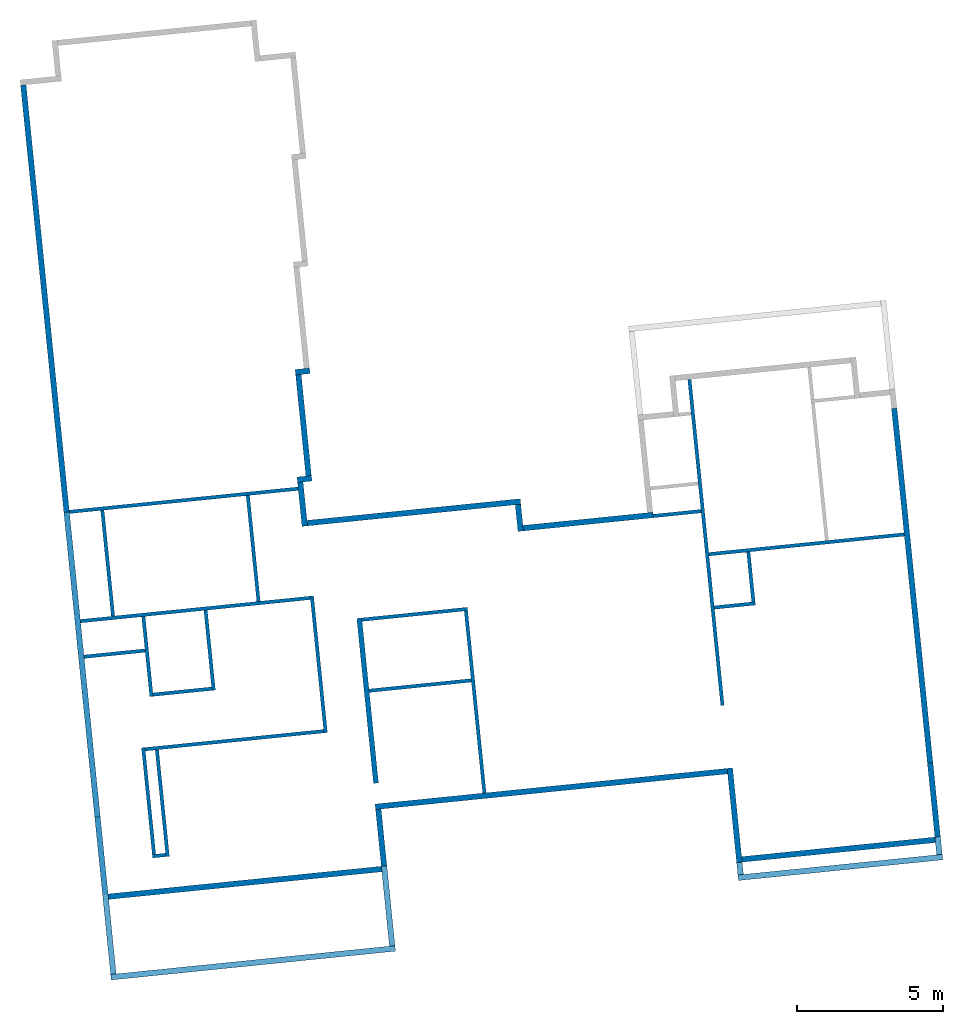
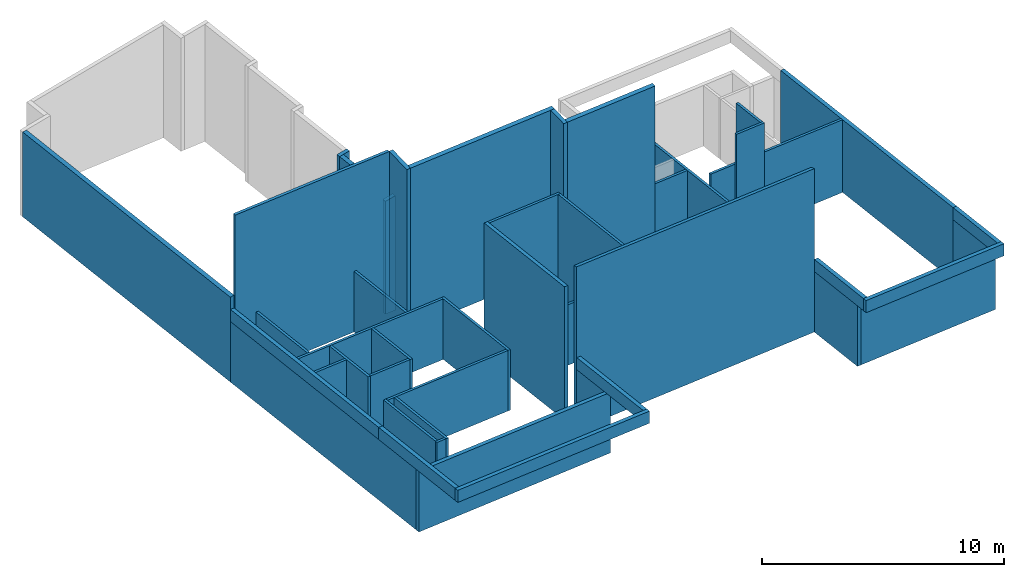
# One storey, part 1 of 2: 45 walls.
"""IFC2X3 building model written with IfcOpenShell, lengths in feet."""

from ifc_helpers import new_model, entity, si_unit, converted_unit, derived_unit, direction, frame, frame_2d, origin, place, context, subcontext, project, spatial, polyline, rectangle, extrude, clip, bounded_halfspace, material, layer, layer_set, layer_usage, type_object, element, save


model = new_model("IFC2X3")

# Units and contexts
model_context = context("Model", 3, precision=0.0001, world=origin(), true_north=direction((0.100810849702482, 0.994905609885814)))
body_context = subcontext(model_context, "Body", "Model", "MODEL_VIEW")
ifc_project = project(units=[converted_unit("LENGTHUNIT", "FOOT", entity("IfcRatioMeasure", 0.3048), si_unit("LENGTHUNIT", "METRE"), dimensions=[1, 0, 0, 0, 0, 0, 0]), converted_unit("AREAUNIT", "SQUARE FOOT", entity("IfcRatioMeasure", 0.09290304), si_unit("AREAUNIT", "SQUARE_METRE"), dimensions=[2, 0, 0, 0, 0, 0, 0]), converted_unit("VOLUMEUNIT", "CUBIC FOOT", entity("IfcRatioMeasure", 0.028316846592), si_unit("VOLUMEUNIT", "CUBIC_METRE"), dimensions=[3, 0, 0, 0, 0, 0, 0]), converted_unit("PLANEANGLEUNIT", "DEGREE", entity("IfcRatioMeasure", 0.0174532925199433), si_unit("PLANEANGLEUNIT", "RADIAN"), dimensions=[0, 0, 0, 0, 0, 0, 0]), si_unit("MASSUNIT", "GRAM", prefix="KILO"), derived_unit("MASSDENSITYUNIT", [(si_unit("MASSUNIT", "GRAM", prefix="KILO"), 1), (si_unit("LENGTHUNIT", "METRE"), -3)]), si_unit("TIMEUNIT", "SECOND"), si_unit("FREQUENCYUNIT", "HERTZ"), si_unit("THERMODYNAMICTEMPERATUREUNIT", "DEGREE_CELSIUS"), derived_unit("THERMALTRANSMITTANCEUNIT", [(si_unit("MASSUNIT", "GRAM", prefix="KILO"), 1), (si_unit("THERMODYNAMICTEMPERATUREUNIT", "KELVIN"), -1), (si_unit("TIMEUNIT", "SECOND"), -3)]), derived_unit("VOLUMETRICFLOWRATEUNIT", [(si_unit("LENGTHUNIT", "METRE"), 3), (si_unit("TIMEUNIT", "SECOND"), -1)]), si_unit("ELECTRICCURRENTUNIT", "AMPERE"), si_unit("ELECTRICVOLTAGEUNIT", "VOLT"), si_unit("POWERUNIT", "WATT"), si_unit("FORCEUNIT", "NEWTON"), si_unit("ILLUMINANCEUNIT", "LUX"), si_unit("LUMINOUSFLUXUNIT", "LUMEN"), si_unit("LUMINOUSINTENSITYUNIT", "CANDELA"), derived_unit("USERDEFINED", [(si_unit("MASSUNIT", "GRAM", prefix="KILO"), -1), (si_unit("LENGTHUNIT", "METRE"), -2), (si_unit("TIMEUNIT", "SECOND"), 3), (si_unit("LUMINOUSFLUXUNIT", "LUMEN"), 1)]), derived_unit("LINEARVELOCITYUNIT", [(si_unit("LENGTHUNIT", "METRE"), 1), (si_unit("TIMEUNIT", "SECOND"), -1)]), si_unit("PRESSUREUNIT", "PASCAL"), derived_unit("USERDEFINED", [(si_unit("LENGTHUNIT", "METRE"), -2), (si_unit("MASSUNIT", "GRAM", prefix="KILO"), 1), (si_unit("TIMEUNIT", "SECOND"), -2)])], contexts=[model_context])

# Site, building, storey
site_placement = place(None, frame((124.447249452883, 13.3868691254093, 0.0), z_axis=(0.0, 0.0, 1.0), x_axis=(0.994905609885814, 0.100810849702482, 0.0)))
site = spatial("IfcSite", under=ifc_project, at=site_placement, CompositionType="ELEMENT")
building_placement = place(site_placement, origin())
building = spatial("IfcBuilding", under=site, at=building_placement, CompositionType="ELEMENT")
storey_placement = place(building_placement, origin())
storey = spatial("IfcBuildingStorey", under=building, at=storey_placement, Name="First Floor", CompositionType="ELEMENT", Elevation=0.0)

# Walls
ifc_material_1 = material(Name="Stucco")
ifc_layer_1 = layer(ifc_material_1, 0.0729166666666667)
ifc_material_2 = material(Name="Plywood, Sheathing")
ifc_layer_2 = layer(ifc_material_2, 0.0416666666666667)
ifc_material_3 = material(Name="Softwood, Lumber")
ifc_layer_3 = layer(ifc_material_3, 0.458333333333333)
ifc_material_4 = material(Name="Gypsum Wall Board")
ifc_layer_4 = layer(ifc_material_4, 0.0520833333333333)
ifc_layer_set_1 = layer_set([ifc_layer_1, ifc_layer_2, ifc_layer_3, ifc_layer_4])
ifc_layer_usage_1 = layer_usage(ifc_layer_set_1, "AXIS2", "NEGATIVE", 0.3125)
wall_type_1 = type_object("IfcWallType", PredefinedType="STANDARD", material=ifc_layer_set_1)
wall_1_placement = place(storey_placement, frame((40.78371364531, -160.576981392437, 0.0), z_axis=(0.0, 0.0, 1.0), x_axis=(0.0, 1.0, 0.0)))
element("IfcWallStandardCase", 1, at=wall_1_placement, inside=storey, type_object=wall_type_1, material=ifc_layer_usage_1, Name="Basic Wall:Exterior - Stucco (light) on Wood Stud", context=body_context, shape_type="SweptSolid", body=[
    extrude(rectangle(XDim=10.6249999999999, YDim=0.625, at=frame_2d((5.31249999999996, 6.66133814775094e-16), x_axis=(-1.0, 0.0))), origin(), (0.0, 0.0, 1.0), 10.0),
])
ifc_layer_usage_2 = layer_usage(ifc_layer_set_1, "AXIS2", "NEGATIVE", 0.3125)
wall_2_placement = place(storey_placement, frame((41.0962136453103, -150.264481392437, 0.0), z_axis=(0.0, 0.0, 1.0), x_axis=(-1.0, 0.0, 0.0)))
element("IfcWallStandardCase", 2, at=wall_2_placement, inside=storey, type_object=wall_type_1, material=ifc_layer_usage_2, Name="Basic Wall:Exterior - Stucco (light) on Wood Stud", context=body_context, shape_type="Clipping", body=[
    clip(extrude(rectangle(XDim=39.625, YDim=0.625, at=frame_2d((20.4375000000002, 4.08006961549745e-15), x_axis=(-1.0, 0.0))), origin(), (0.0, 0.0, 1.0), 26.9900427781354), bounded_halfspace(frame((0.0, -0.3125, 26.8795661415278), z_axis=(0.0, 0.174064214161642, -0.984734303935985), x_axis=(1.0, 0.0, 0.0)), True, frame((0.0, -0.3125, 26.8795661415278)), polyline([(0.0, 0.0), (39.6250000000002, 0.0), (40.2500000000002, 0.0), (40.2500000000002, 0.625), (0.0, 0.625), (0.0, 0.0)]))),
])
ifc_layer_usage_3 = layer_usage(ifc_layer_set_1, "AXIS2", "NEGATIVE", 0.3125)
wall_3_placement = place(storey_placement, frame((1.47121364531006, -157.264481392437, 0.0), z_axis=(0.0, 0.0, 1.0), x_axis=(-1.0, 0.0, 0.0)))
element("IfcWallStandardCase", 3, at=wall_3_placement, inside=storey, type_object=wall_type_1, material=ifc_layer_usage_3, Name="Basic Wall:Exterior - Stucco (light) on Wood Stud", context=body_context, shape_type="SweptSolid", body=[
    extrude(rectangle(XDim=32.0, YDim=0.625, at=frame_2d((16.0, 0.0), x_axis=(-1.0, 0.0))), origin(), (0.0, 0.0, 1.0), 10.0),
])
ifc_layer_usage_4 = layer_usage(ifc_layer_set_1, "AXIS2", "NEGATIVE", 0.3125)
wall_4_placement = place(storey_placement, frame((-1.52878635468974, -100.951981392437, 0.0), z_axis=(0.0, 0.0, 1.0), x_axis=(-1.0, 0.0, 0.0)))
element("IfcWallStandardCase", 4, at=wall_4_placement, inside=storey, type_object=wall_type_1, material=ifc_layer_usage_4, Name="Basic Wall:Exterior - Stucco (light) on Wood Stud", context=body_context, shape_type="Clipping", body=[
    clip(extrude(rectangle(XDim=1.625, YDim=0.625, at=frame_2d((0.8125, 0.0), x_axis=(-1.0, 0.0))), origin(), (0.0, 0.0, 1.0), 19.1135599720343), bounded_halfspace(frame((0.0, -0.3125, 19.1135599720343), z_axis=(-0.173648177666572, 0.0, -0.984807753012271), x_axis=(0.0, 1.0, 0.0)), True, frame((0.0, -0.3125, 19.1135599720343)), polyline([(0.0, 0.0), (0.625, 0.0), (1.625, 0.0), (1.625, 0.625), (1.0, 0.625), (0.0, 0.625), (0.0, 0.0)]))),
])
ifc_layer_usage_5 = layer_usage(ifc_layer_set_1, "AXIS2", "NEGATIVE", 0.3125)
wall_5_placement = place(storey_placement, frame((-2.84128635468974, -101.264481392437, 0.0), z_axis=(0.0, 0.0, 1.0), x_axis=(0.0, -1.0, 0.0)))
element("IfcWallStandardCase", 5, at=wall_5_placement, inside=storey, type_object=wall_type_1, material=ifc_layer_usage_5, Name="Basic Wall:Exterior - Stucco (light) on Wood Stud", context=body_context, shape_type="Clipping", body=[
    clip(extrude(rectangle(XDim=11.375, YDim=0.625, at=frame_2d((5.6875, 0.0), x_axis=(-1.0, 0.0))), origin(), (0.0, 0.0, 1.0), 18.9372329913262), bounded_halfspace(frame((0.0, -0.3125, 18.8270286283836), z_axis=(0.0, 0.173648177666572, -0.984807753012271), x_axis=(1.0, 0.0, 0.0)), True, frame((0.0, -0.3125, 18.8270286283836)), polyline([(0.0, 0.0), (11.375, 0.0), (11.375, 0.625), (0.0, 0.625), (0.0, 0.0)]))),
])
ifc_layer_usage_6 = layer_usage(ifc_layer_set_1, "AXIS2", "NEGATIVE", 0.3125)
wall_6_placement = place(storey_placement, frame((-2.52878635468974, -112.951981392437, 0.0), z_axis=(0.0, 0.0, 1.0), x_axis=(-1.0, 0.0, 0.0)))
element("IfcWallStandardCase", 6, at=wall_6_placement, inside=storey, type_object=wall_type_1, material=ifc_layer_usage_6, Name="Basic Wall:Exterior - Stucco (light) on Wood Stud", context=body_context, shape_type="Clipping", body=[
    clip(extrude(rectangle(XDim=1.625, YDim=0.625, at=frame_2d((0.8125, 0.0), x_axis=(-1.0, 0.0))), origin(), (0.0, 0.0, 1.0), 18.937232991326), bounded_halfspace(frame((0.0, -0.3125, 18.937232991326), z_axis=(-0.173648177666572, 0.0, -0.984807753012271), x_axis=(0.0, 1.0, 0.0)), True, frame((0.0, -0.3125, 18.937232991326)), polyline([(0.0, 0.0), (0.625, 0.0), (1.625, 0.0), (1.625, 0.625), (1.0, 0.625), (0.0, 0.625), (0.0, 0.0)]))),
])
ifc_layer_usage_7 = layer_usage(ifc_layer_set_1, "AXIS2", "NEGATIVE", 0.3125)
wall_7_placement = place(storey_placement, frame((-3.84128635468974, -113.264481392437, 0.0), z_axis=(0.0, 0.0, 1.0), x_axis=(0.0, -1.0, 0.0)))
element("IfcWallStandardCase", 7, at=wall_7_placement, inside=storey, type_object=wall_type_1, material=ifc_layer_usage_7, Name="Basic Wall:Exterior - Stucco (light) on Wood Stud", context=body_context, shape_type="Clipping", body=[
    clip(clip(extrude(rectangle(XDim=4.9375, YDim=0.625, at=frame_2d((2.46875, 0.0), x_axis=(-1.0, 0.0))), origin(), (0.0, 0.0, 1.0), 27.4185537193469), bounded_halfspace(frame((0.0, -0.3125, 18.6507016476753), z_axis=(0.0, 0.173648177666572, -0.984807753012271), x_axis=(1.0, 0.0, 0.0)), True, frame((0.0, -0.3125, 18.6507016476753)), polyline([(0.0, 0.0), (0.824995650978366, 0.0), (0.824995650978366, 0.624999999999999), (0.0, 0.625), (0.0, 0.0)]))), bounded_halfspace(frame((0.824995650978479, -0.3125, 27.4185537193469), z_axis=(-0.173648177666906, 0.0, -0.984807753012212), x_axis=(0.0, -1.0, 0.0)), True, frame((0.824995650978479, -0.3125, 27.4185537193469)), polyline([(0.0, 0.0), (0.0604210156881919, 0.0), (4.11250434902152, 0.0), (4.11250434902152, 0.625), (3.48750434902152, 0.625), (0.0, 0.625), (0.0, 0.0)]))),
])
ifc_layer_usage_8 = layer_usage(ifc_layer_set_1, "AXIS2", "NEGATIVE", 0.3125)
wall_8_placement = place(storey_placement, frame((20.4712136453103, -120.889481392437, 0.0)))
element("IfcWallStandardCase", 8, at=wall_8_placement, inside=storey, type_object=wall_type_1, material=ifc_layer_usage_8, Name="Basic Wall:Exterior - Stucco (light) on Wood Stud", context=body_context, shape_type="Clipping", body=[
    clip(extrude(rectangle(XDim=14.6249833333333, YDim=0.625, at=frame_2d((7.31249166666666, 0.0), x_axis=(-1.0, 0.0))), origin(), (0.0, 0.0, 1.0), 26.2746316651512), bounded_halfspace(frame((0.0, -0.3125, 26.1644273022084), z_axis=(0.0, 0.173648177666906, -0.984807753012212), x_axis=(-1.0, 0.0, 0.0)), True, frame((0.0, -0.3125, 26.1644273022084)), polyline([(0.0, 0.0), (14.6249833333333, 0.0), (14.6249833333333, 0.625), (0.0, 0.625), (0.0, 0.0)]))),
])
ifc_layer_usage_9 = layer_usage(ifc_layer_set_1, "AXIS2", "NEGATIVE", 0.3125)
wall_9_placement = place(storey_placement, frame((63.4712136453102, -160.264481392437, 0.0), z_axis=(0.0, 0.0, 1.0), x_axis=(-1.0, 0.0, 0.0)))
element("IfcWallStandardCase", 9, at=wall_9_placement, inside=storey, type_object=wall_type_1, material=ifc_layer_usage_9, Name="Basic Wall:Exterior - Stucco (light) on Wood Stud", context=body_context, shape_type="SweptSolid", body=[
    extrude(rectangle(XDim=22.3750000000002, YDim=0.625, at=frame_2d((11.1875000000001, 3.08086889333481e-15), x_axis=(-1.0, 0.0))), origin(), (0.0, 0.0, 1.0), 10.0),
])
ifc_layer_usage_10 = layer_usage(ifc_layer_set_1, "AXIS2", "NEGATIVE", 0.3125)
wall_10_placement = place(storey_placement, frame((63.1587136453103, -111.728023059104, 0.0), z_axis=(0.0, 0.0, 1.0), x_axis=(0.0, -1.0, 0.0)))
element("IfcWallStandardCase", 10, at=wall_10_placement, inside=storey, type_object=wall_type_1, material=ifc_layer_usage_10, Name="Basic Wall:Exterior - Stucco (light) on Wood Stud", context=body_context, shape_type="SweptSolid", body=[
    extrude(rectangle(XDim=39.9114583333334, YDim=0.625, at=frame_2d((19.9557291666667, 0.0), x_axis=(-1.0, 0.0))), origin(), (0.0, 0.0, 1.0), 12.0),
])
ifc_layer_usage_11 = layer_usage(ifc_layer_set_1, "AXIS2", "NEGATIVE", 0.3125)
wall_11_placement = place(storey_placement, frame((63.1587136453102, -151.639481392437, 0.0), z_axis=(0.0, 0.0, 1.0), x_axis=(0.0, -1.0, 0.0)))
element("IfcWallStandardCase", 11, at=wall_11_placement, inside=storey, type_object=wall_type_1, material=ifc_layer_usage_11, Name="Basic Wall:Exterior - Stucco (light) on Wood Stud", context=body_context, shape_type="SweptSolid", body=[
    extrude(rectangle(XDim=8.31249999999991, YDim=0.625, at=frame_2d((4.15624999999996, -1.19348975147204e-15), x_axis=(-1.0, 0.0))), origin(), (0.0, 0.0, 1.0), 10.0),
])
ifc_layer_usage_12 = layer_usage(ifc_layer_set_1, "AXIS2", "NEGATIVE", 0.3125)
wall_12_placement = place(storey_placement, frame((1.15871364531007, -150.576981392437, 0.0), z_axis=(0.0, 0.0, 1.0), x_axis=(0.0, -1.0, 0.0)))
element("IfcWallStandardCase", 12, at=wall_12_placement, inside=storey, type_object=wall_type_1, material=ifc_layer_usage_12, Name="Basic Wall:Exterior - Stucco (light) on Wood Stud", context=body_context, shape_type="SweptSolid", body=[
    extrude(rectangle(XDim=6.375, YDim=0.625, at=frame_2d((3.1875, 5.55111512312578e-17), x_axis=(-1.0, 0.0))), origin(), (0.0, 0.0, 1.0), 10.0),
])
ifc_layer_usage_13 = layer_usage(ifc_layer_set_1, "AXIS2", "NEGATIVE", 0.3125)
wall_13_placement = place(storey_placement, frame((-30.2162863546899, -156.951981392437, 0.0), z_axis=(0.0, 0.0, 1.0), x_axis=(0.0, 1.0, 0.0)))
element("IfcWallStandardCase", 13, at=wall_13_placement, inside=storey, type_object=wall_type_1, material=ifc_layer_usage_13, Name="Basic Wall:Exterior - Stucco (light) on Wood Stud", context=body_context, shape_type="SweptSolid", body=[
    extrude(rectangle(XDim=43.0, YDim=0.625, at=frame_2d((21.5, -4.16333634234434e-16), x_axis=(-1.0, 0.0))), origin(), (0.0, 0.0, 1.0), 10.0),
])
ifc_layer_usage_14 = layer_usage(ifc_layer_set_1, "AXIS2", "NEGATIVE", 0.3125)
wall_14_placement = place(storey_placement, frame((-30.2162863546899, -148.264481392437, 10.0), z_axis=(0.0, 0.0, 1.0), x_axis=(0.0, 1.0, 0.0)))
element("IfcWallStandardCase", 14, at=wall_14_placement, inside=storey, type_object=wall_type_1, material=ifc_layer_usage_14, Name="Basic Wall:Exterior - Stucco (light) on Wood Stud", context=body_context, shape_type="SweptSolid", body=[
    extrude(rectangle(XDim=34.3124999999999, YDim=0.625, at=frame_2d((17.1562499999999, -1.66533453693773e-16), x_axis=(-1.0, 0.0))), origin(), (0.0, 0.0, 1.0), 2.0),
])
ifc_layer_usage_15 = layer_usage(ifc_layer_set_1, "AXIS2", "NEGATIVE", 0.3125)
wall_15_placement = place(storey_placement, frame((-30.2162863546899, -113.951981392437, 0.0), z_axis=(0.0, 0.0, 1.0), x_axis=(0.0, 1.0, 0.0)))
element("IfcWallStandardCase", 15, at=wall_15_placement, inside=storey, type_object=wall_type_1, material=ifc_layer_usage_15, Name="Basic Wall:Exterior - Stucco (light) on Wood Stud", context=body_context, shape_type="Clipping", body=[
    clip(extrude(rectangle(XDim=48.0625, YDim=0.625, at=frame_2d((24.03125, -3.33066907387547e-16), x_axis=(-1.0, 0.0))), origin(), (0.0, 0.0, 1.0), 14.1102818944428), bounded_halfspace(frame((0.0, -0.312499999999999, 14.110281894442), z_axis=(0.0, -0.173648177666572, -0.984807753012271), x_axis=(-1.0, 0.0, 0.0)), True, frame((0.0, -0.312499999999999, 14.110281894442)), polyline([(0.0, 0.0), (48.0625, 0.0), (48.0625, 0.624999999999999), (0.0, 0.625), (0.0, 0.0)]))),
])
ifc_material_5 = material(Name="Stucco - Black")
ifc_layer_5 = layer(ifc_material_5, 0.0729166666666667)
ifc_layer_6 = layer(ifc_material_2, 0.0416666666666667)
ifc_layer_7 = layer(ifc_material_3, 0.458333333333333)
ifc_layer_8 = layer(ifc_material_4, 0.0520833333333333)
ifc_layer_set_2 = layer_set([ifc_layer_5, ifc_layer_6, ifc_layer_7, ifc_layer_8])
ifc_layer_usage_16 = layer_usage(ifc_layer_set_2, "AXIS2", "NEGATIVE", 0.3125)
wall_type_2 = type_object("IfcWallType", PredefinedType="STANDARD", material=ifc_layer_set_2)
wall_16_placement = place(storey_placement, frame((-3.52878635468974, -117.889481392437, 0.0)))
element("IfcWallStandardCase", 16, at=wall_16_placement, inside=storey, type_object=wall_type_2, material=ifc_layer_usage_16, Name="Basic Wall:Exterior - Stucco (dark) on Wood Stud", context=body_context, shape_type="Clipping", body=[
    clip(extrude(rectangle(XDim=24.0, YDim=0.625, at=frame_2d((12.0, 0.0), x_axis=(-1.0, 0.0))), origin(), (0.0, 0.0, 1.0), 26.8036126072765), bounded_halfspace(frame((0.0, -0.3125, 26.6934082443336), z_axis=(0.0, 0.173648177666906, -0.984807753012212), x_axis=(-1.0, 0.0, 0.0)), True, frame((0.0, -0.3125, 26.6934082443336)), polyline([(0.0, 0.0), (23.375, 0.0), (24.0, 0.0), (24.0, 0.625), (0.0, 0.625), (0.0, 0.0)]))),
])
ifc_layer_usage_17 = layer_usage(ifc_layer_set_2, "AXIS2", "NEGATIVE", 0.3125)
wall_17_placement = place(storey_placement, frame((20.1587136453103, -118.201981392437, 0.0), z_axis=(0.0, 0.0, 1.0), x_axis=(0.0, -1.0, 0.0)))
element("IfcWallStandardCase", 17, at=wall_17_placement, inside=storey, type_object=wall_type_2, material=ifc_layer_usage_17, Name="Basic Wall:Exterior - Stucco (dark) on Wood Stud", context=body_context, shape_type="Clipping", body=[
    clip(extrude(rectangle(XDim=3.0, YDim=0.625, at=frame_2d((1.5, 0.0), x_axis=(-1.0, 0.0))), origin(), (0.0, 0.0, 1.0), 26.6934082443337), bounded_halfspace(frame((0.0, -0.3125, 26.6934082443337), z_axis=(-0.173648177666906, 0.0, -0.984807753012212), x_axis=(0.0, -1.0, 0.0)), True, frame((0.0, -0.3125, 26.6934082443337)), polyline([(0.0, 0.0), (3.0, 0.0), (3.0, 0.625), (2.375, 0.625), (0.0, 0.625), (0.0, 0.0)]))),
])
ifc_layer_usage_18 = layer_usage(ifc_layer_set_2, "AXIS2", "NEGATIVE", 0.3125)
wall_18_placement = place(storey_placement, frame((63.1587136453103, -151.639481392437, 10.0), z_axis=(0.0, 0.0, 1.0), x_axis=(0.0, -1.0, 0.0)))
element("IfcWallStandardCase", 18, at=wall_18_placement, inside=storey, type_object=wall_type_2, material=ifc_layer_usage_18, Name="Basic Wall:Exterior - Stucco (dark) on Wood Stud", context=body_context, shape_type="SweptSolid", body=[
    extrude(rectangle(XDim=10.3124999999999, YDim=0.625, at=frame_2d((5.15624999999996, 0.0), x_axis=(-1.0, 0.0))), origin(), (0.0, 0.0, 1.0), 2.0),
])
ifc_layer_usage_19 = layer_usage(ifc_layer_set_2, "AXIS2", "NEGATIVE", 0.3125)
wall_19_placement = place(storey_placement, frame((63.4712136453103, -162.264481392437, 10.0), z_axis=(0.0, 0.0, 1.0), x_axis=(-1.0, 0.0, 0.0)))
element("IfcWallStandardCase", 19, at=wall_19_placement, inside=storey, type_object=wall_type_2, material=ifc_layer_usage_19, Name="Basic Wall:Exterior - Stucco (dark) on Wood Stud", context=body_context, shape_type="SweptSolid", body=[
    extrude(rectangle(XDim=23.0, YDim=0.625, at=frame_2d((11.5, -2.77555756156289e-16), x_axis=(-1.0, 0.0))), origin(), (0.0, 0.0, 1.0), 2.0),
])
ifc_layer_usage_20 = layer_usage(ifc_layer_set_2, "AXIS2", "NEGATIVE", 0.3125)
wall_20_placement = place(storey_placement, frame((40.7837136453103, -161.951981392437, 10.0), z_axis=(0.0, 0.0, 1.0), x_axis=(0.0, 1.0, 0.0)))
element("IfcWallStandardCase", 20, at=wall_20_placement, inside=storey, type_object=wall_type_2, material=ifc_layer_usage_20, Name="Basic Wall:Exterior - Stucco (dark) on Wood Stud", context=body_context, shape_type="SweptSolid", body=[
    extrude(rectangle(XDim=11.3749999999999, YDim=0.625, at=frame_2d((5.68749999999994, -1.97064586870965e-15), x_axis=(-1.0, 0.0))), origin(), (0.0, 0.0, 1.0), 2.0),
])
ifc_layer_usage_21 = layer_usage(ifc_layer_set_2, "AXIS2", "NEGATIVE", 0.3125)
wall_21_placement = place(storey_placement, frame((1.47121364531005, -166.264481392437, 10.0), z_axis=(0.0, 0.0, 1.0), x_axis=(-1.0, 0.0, 0.0)))
element("IfcWallStandardCase", 21, at=wall_21_placement, inside=storey, type_object=wall_type_2, material=ifc_layer_usage_21, Name="Basic Wall:Exterior - Stucco (dark) on Wood Stud", context=body_context, shape_type="SweptSolid", body=[
    extrude(rectangle(XDim=32.0, YDim=0.625, at=frame_2d((16.0, 5.55111512312578e-16), x_axis=(-1.0, 0.0))), origin(), (0.0, 0.0, 1.0), 2.0),
])
ifc_layer_usage_22 = layer_usage(ifc_layer_set_2, "AXIS2", "NEGATIVE", 0.3125)
wall_22_placement = place(storey_placement, frame((-30.21628635469, -165.951981392437, 10.0), z_axis=(0.0, 0.0, 1.0), x_axis=(0.0, 1.0, 0.0)))
element("IfcWallStandardCase", 22, at=wall_22_placement, inside=storey, type_object=wall_type_2, material=ifc_layer_usage_22, Name="Basic Wall:Exterior - Stucco (dark) on Wood Stud", context=body_context, shape_type="SweptSolid", body=[
    extrude(rectangle(XDim=17.6875, YDim=0.625, at=frame_2d((8.84375, -3.88578058618805e-16), x_axis=(-1.0, 0.0))), origin(), (0.0, 0.0, 1.0), 2.0),
])
ifc_layer_usage_23 = layer_usage(ifc_layer_set_2, "AXIS2", "NEGATIVE", 0.3125)
wall_23_placement = place(storey_placement, frame((1.15871364531007, -150.576981392437, 10.0), z_axis=(0.0, 0.0, 1.0), x_axis=(0.0, -1.0, 0.0)))
element("IfcWallStandardCase", 23, at=wall_23_placement, inside=storey, type_object=wall_type_2, material=ifc_layer_usage_23, Name="Basic Wall:Exterior - Stucco (dark) on Wood Stud", context=body_context, shape_type="SweptSolid", body=[
    extrude(rectangle(XDim=15.375, YDim=0.625, at=frame_2d((7.6875, 0.0), x_axis=(-1.0, 0.0))), origin(), (0.0, 0.0, 1.0), 2.0),
])
ifc_layer_9 = layer(ifc_material_4, 0.0520833333333333)
ifc_layer_10 = layer(ifc_material_3, 0.291666666666667)
ifc_layer_11 = layer(ifc_material_4, 0.0520833333333333)
ifc_layer_set_3 = layer_set([ifc_layer_9, ifc_layer_10, ifc_layer_11])
ifc_layer_usage_24 = layer_usage(ifc_layer_set_3, "AXIS2", "NEGATIVE", 0.197916666666667)
wall_type_3 = type_object("IfcWallType", PredefinedType="STANDARD", material=ifc_layer_set_3)
wall_24_placement = place(storey_placement, frame((40.6691136453103, -106.201981392437, 0.0), z_axis=(0.0, 0.0, 1.0), x_axis=(0.0, -1.0, 0.0)))
element("IfcWallStandardCase", 24, at=wall_24_placement, inside=storey, type_object=wall_type_3, material=ifc_layer_usage_24, context=body_context, shape_type="SweptSolid", body=[
    extrude(rectangle(XDim=36.6875, YDim=0.395833333333329, at=frame_2d((18.34375, 9.0205620750794e-16), x_axis=(-1.0, 0.0))), origin(), (0.0, 0.0, 1.0), 10.0),
])
ifc_layer_usage_25 = layer_usage(ifc_layer_set_3, "AXIS2", "NEGATIVE", 0.197916666666667)
wall_25_placement = place(storey_placement, frame((40.8670303119769, -125.889481392437, 0.0)))
element("IfcWallStandardCase", 25, at=wall_25_placement, inside=storey, type_object=wall_type_3, material=ifc_layer_usage_25, context=body_context, shape_type="SweptSolid", body=[
    extrude(rectangle(XDim=21.9791833333334, YDim=0.395833333333343, at=frame_2d((10.9895916666667, -1.38777878078145e-15), x_axis=(-1.0, 0.0))), origin(), (0.0, 0.0, 1.0), 12.0),
])
ifc_layer_usage_26 = layer_usage(ifc_layer_set_3, "AXIS2", "NEGATIVE", 0.197916666666667)
wall_26_placement = place(storey_placement, frame((35.0961969786436, -121.00406472577, 0.0)))
element("IfcWallStandardCase", 26, at=wall_26_placement, inside=storey, type_object=wall_type_3, material=ifc_layer_usage_26, context=body_context, shape_type="SweptSolid", body=[
    extrude(rectangle(XDim=5.37499999999999, YDim=0.395833333333343, at=frame_2d((2.68749999999999, -1.66533453693773e-16), x_axis=(-1.0, 0.0))), origin(), (0.0, 0.0, 1.0), 10.0),
])
ifc_layer_usage_27 = layer_usage(ifc_layer_set_3, "AXIS2", "NEGATIVE", 0.197916666666667)
wall_27_placement = place(storey_placement, frame((40.8670303119769, -131.889481392437, 0.0)))
element("IfcWallStandardCase", 27, at=wall_27_placement, inside=storey, type_object=wall_type_3, material=ifc_layer_usage_27, context=body_context, shape_type="SweptSolid", body=[
    extrude(rectangle(XDim=4.61460000000001, YDim=0.395833333333343, at=frame_2d((2.30730000000001, -1.4210854715202e-14), x_axis=(-1.0, 0.0))), origin(), (0.0, 0.0, 1.0), 22.0),
])
ifc_layer_usage_28 = layer_usage(ifc_layer_set_3, "AXIS2", "NEGATIVE", 0.197916666666667)
wall_28_placement = place(storey_placement, frame((45.2837136453102, -131.69156472577, 0.0), z_axis=(0.0, 0.0, 1.0), x_axis=(0.0, 1.0, 0.0)))
element("IfcWallStandardCase", 28, at=wall_28_placement, inside=storey, type_object=wall_type_3, material=ifc_layer_usage_28, context=body_context, shape_type="SweptSolid", body=[
    extrude(rectangle(XDim=5.60416666666667, YDim=0.395833333333329, at=frame_2d((2.80208333333334, -2.35922392732846e-16), x_axis=(-1.0, 0.0))), origin(), (0.0, 0.0, 1.0), 22.0),
])
ifc_layer_usage_29 = layer_usage(ifc_layer_set_3, "AXIS2", "NEGATIVE", 0.197916666666667)
wall_29_placement = place(storey_placement, frame((1.47121364531011, -129.264481392437, 0.0)))
element("IfcWallStandardCase", 29, at=wall_29_placement, inside=storey, type_object=wall_type_3, material=ifc_layer_usage_29, context=body_context, shape_type="SweptSolid", body=[
    extrude(rectangle(XDim=11.8854166666667, YDim=0.395833333333314, at=frame_2d((5.94270833333333, 0.0), x_axis=(-1.0, 0.0))), origin(), (0.0, 0.0, 1.0), 22.0),
])
ifc_layer_usage_30 = layer_usage(ifc_layer_set_3, "AXIS2", "NEGATIVE", 0.197916666666667)
wall_30_placement = place(storey_placement, frame((13.1587136453101, -129.462398059104, 0.0), z_axis=(0.0, 0.0, 1.0), x_axis=(0.0, -1.0, 0.0)))
element("IfcWallStandardCase", 30, at=wall_30_placement, inside=storey, type_object=wall_type_3, material=ifc_layer_usage_30, context=body_context, shape_type="SweptSolid", body=[
    extrude(rectangle(XDim=20.4895833333334, YDim=0.395833333333332, at=frame_2d((10.2447916666667, -4.16333634234434e-16), x_axis=(-1.0, 0.0))), origin(), (0.0, 0.0, 1.0), 22.0),
])
ifc_layer_usage_31 = layer_usage(ifc_layer_set_3, "AXIS2", "NEGATIVE", 0.197916666666667)
wall_31_placement = place(storey_placement, frame((1.47121364531009, -137.264481392437, 0.0)))
element("IfcWallStandardCase", 31, at=wall_31_placement, inside=storey, type_object=wall_type_3, material=ifc_layer_usage_31, context=body_context, shape_type="SweptSolid", body=[
    extrude(rectangle(XDim=11.4895833333333, YDim=0.395833333333314, at=frame_2d((5.74479166666666, -6.10622663543836e-16), x_axis=(-1.0, 0.0))), origin(), (0.0, 0.0, 1.0), 10.0),
])
ifc_layer_usage_32 = layer_usage(ifc_layer_set_3, "AXIS2", "NEGATIVE", 0.197916666666667)
wall_32_placement = place(storey_placement, frame((-3.84128635468991, -126.058795295593, 0.0), z_axis=(0.0, 0.0, 1.0), x_axis=(0.0, -1.0, 0.0)))
element("IfcWallStandardCase", 32, at=wall_32_placement, inside=storey, type_object=wall_type_3, material=ifc_layer_usage_32, context=body_context, shape_type="SweptSolid", body=[
    extrude(rectangle(XDim=15.3958333333333, YDim=0.395833333333333, at=frame_2d((7.69791666666666, -2.08166817117217e-16), x_axis=(-1.0, 0.0))), origin(), (0.0, 0.0, 1.0), 10.0),
])
ifc_layer_usage_33 = layer_usage(ifc_layer_set_3, "AXIS2", "NEGATIVE", 0.197916666666667)
wall_33_placement = place(storey_placement, frame((-4.0392030213566, -141.25671196226, 0.0), z_axis=(0.0, 0.0, 1.0), x_axis=(-1.0, 0.0, 0.0)))
element("IfcWallStandardCase", 33, at=wall_33_placement, inside=storey, type_object=wall_type_3, material=ifc_layer_usage_33, context=body_context, shape_type="SweptSolid", body=[
    extrude(rectangle(XDim=20.1041666666667, YDim=0.395833333333314, at=frame_2d((10.0520833333333, 0.0), x_axis=(-1.0, 0.0))), origin(), (0.0, 0.0, 1.0), 10.0),
])
ifc_layer_usage_34 = layer_usage(ifc_layer_set_3, "AXIS2", "NEGATIVE", 0.197916666666667)
wall_34_placement = place(storey_placement, frame((-22.8412863546899, -141.454628628926, 0.0), z_axis=(0.0, 0.0, 1.0), x_axis=(0.0, -1.0, 0.0)))
element("IfcWallStandardCase", 34, at=wall_34_placement, inside=storey, type_object=wall_type_3, material=ifc_layer_usage_34, context=body_context, shape_type="SweptSolid", body=[
    extrude(rectangle(XDim=12.0, YDim=0.395833333333336, at=frame_2d((6.0, 2.63677968348475e-16), x_axis=(-1.0, 0.0))), origin(), (0.0, 0.0, 1.0), 10.0),
])
ifc_layer_usage_35 = layer_usage(ifc_layer_set_3, "AXIS2", "NEGATIVE", 0.197916666666667)
wall_35_placement = place(storey_placement, frame((-23.0392030213566, -153.25671196226, 0.0), z_axis=(0.0, 0.0, 1.0), x_axis=(-1.0, 0.0, 0.0)))
element("IfcWallStandardCase", 35, at=wall_35_placement, inside=storey, type_object=wall_type_3, material=ifc_layer_usage_35, context=body_context, shape_type="SweptSolid", body=[
    extrude(rectangle(XDim=1.5, YDim=0.395833333333314, at=frame_2d((0.750000000000002, 0.0), x_axis=(-1.0, 0.0))), origin(), (0.0, 0.0, 1.0), 10.0),
])
ifc_layer_usage_36 = layer_usage(ifc_layer_set_3, "AXIS2", "NEGATIVE", 0.197916666666667)
wall_36_placement = place(storey_placement, frame((-24.3412863546899, -153.058795295593, 0.0), z_axis=(0.0, 0.0, 1.0), x_axis=(0.0, 1.0, 0.0)))
element("IfcWallStandardCase", 36, at=wall_36_placement, inside=storey, type_object=wall_type_3, material=ifc_layer_usage_36, context=body_context, shape_type="SweptSolid", body=[
    extrude(rectangle(XDim=12.0, YDim=0.395833333333336, at=frame_2d((6.0, 7.21644966006352e-16), x_axis=(-1.0, 0.0))), origin(), (0.0, 0.0, 1.0), 10.0),
])
ifc_layer_usage_37 = layer_usage(ifc_layer_set_3, "AXIS2", "NEGATIVE", 0.197916666666667)
wall_37_placement = place(storey_placement, frame((-4.03920302135657, -126.25671196226, 0.0), z_axis=(0.0, 0.0, 1.0), x_axis=(-1.0, 0.0, 0.0)))
element("IfcWallStandardCase", 37, at=wall_37_placement, inside=storey, type_object=wall_type_3, material=ifc_layer_usage_37, context=body_context, shape_type="SweptSolid", body=[
    extrude(rectangle(XDim=25.8645833333333, YDim=0.395833333333343, at=frame_2d((12.9322916666667, -8.18789480661053e-16), x_axis=(-1.0, 0.0))), origin(), (0.0, 0.0, 1.0), 10.0),
])
ifc_layer_usage_38 = layer_usage(ifc_layer_set_3, "AXIS2", "NEGATIVE", 0.197916666666667)
wall_38_placement = place(storey_placement, frame((-15.8412863546899, -135.454628628926, 0.0), z_axis=(0.0, 0.0, 1.0), x_axis=(0.0, 1.0, 0.0)))
element("IfcWallStandardCase", 38, at=wall_38_placement, inside=storey, type_object=wall_type_3, material=ifc_layer_usage_38, context=body_context, shape_type="SweptSolid", body=[
    extrude(rectangle(XDim=9.00000000000003, YDim=0.395833333333334, at=frame_2d((4.50000000000001, 5.68989300120393e-16), x_axis=(-1.0, 0.0))), origin(), (0.0, 0.0, 1.0), 10.0),
])
ifc_layer_usage_39 = layer_usage(ifc_layer_set_3, "AXIS2", "NEGATIVE", 0.197916666666667)
wall_39_placement = place(storey_placement, frame((-22.8412863546899, -126.454628628926, 0.0), z_axis=(0.0, 0.0, 1.0), x_axis=(0.0, -1.0, 0.0)))
element("IfcWallStandardCase", 39, at=wall_39_placement, inside=storey, type_object=wall_type_3, material=ifc_layer_usage_39, context=body_context, shape_type="SweptSolid", body=[
    extrude(rectangle(XDim=9.00000000000001, YDim=0.395833333333336, at=frame_2d((4.50000000000001, 0.0), x_axis=(-1.0, 0.0))), origin(), (0.0, 0.0, 1.0), 10.0),
])
ifc_layer_usage_40 = layer_usage(ifc_layer_set_3, "AXIS2", "NEGATIVE", 0.197916666666667)
wall_40_placement = place(storey_placement, frame((-22.6433696880232, -135.25671196226, 0.0)))
element("IfcWallStandardCase", 40, at=wall_40_placement, inside=storey, type_object=wall_type_3, material=ifc_layer_usage_40, context=body_context, shape_type="SweptSolid", body=[
    extrude(rectangle(XDim=6.60416666666666, YDim=0.395833333333314, at=frame_2d((3.30208333333333, 2.85882428840978e-15), x_axis=(-1.0, 0.0))), origin(), (0.0, 0.0, 1.0), 10.0),
])
ifc_layer_usage_41 = layer_usage(ifc_layer_set_3, "AXIS2", "NEGATIVE", 0.197916666666667)
wall_41_placement = place(storey_placement, frame((-29.9037863546899, -130.25671196226, 0.0)))
element("IfcWallStandardCase", 41, at=wall_41_placement, inside=storey, type_object=wall_type_3, material=ifc_layer_usage_41, context=body_context, shape_type="SweptSolid", body=[
    extrude(rectangle(XDim=6.86458333333333, YDim=0.395833333333314, at=frame_2d((3.43229166666666, -9.85322934354826e-16), x_axis=(-1.0, 0.0))), origin(), (0.0, 0.0, 1.0), 10.0),
])
ifc_layer_usage_42 = layer_usage(ifc_layer_set_3, "AXIS2", "NEGATIVE", 0.197916666666667)
wall_42_placement = place(storey_placement, frame((-4.15378635468974, -113.951981392437, 0.0), z_axis=(0.0, 0.0, 1.0), x_axis=(-1.0, 0.0, 0.0)))
element("IfcWallStandardCase", 42, at=wall_42_placement, inside=storey, type_object=wall_type_3, material=ifc_layer_usage_42, context=body_context, shape_type="Clipping", body=[
    clip(extrude(rectangle(XDim=25.7500000000001, YDim=0.395833333333343, at=frame_2d((12.8750000000001, -1.01307850997046e-15), x_axis=(-1.0, 0.0))), origin(), (0.0, 0.0, 1.0), 27.4776959606097), bounded_halfspace(frame((0.0, -0.197916666666657, 27.4776959606097), z_axis=(0.0, -0.173648177666906, -0.984807753012212), x_axis=(1.0, 0.0, 0.0)), True, frame((0.0, -0.197916666666657, 27.4776959606097)), polyline([(0.0, 0.0), (25.7500000000001, 0.0), (25.7500000000001, 0.395833333333329), (0.0, 0.395833333333329), (0.0, 0.335412317645137), (0.0, 0.0)]))),
])
ifc_layer_usage_43 = layer_usage(ifc_layer_set_3, "AXIS2", "NEGATIVE", 0.197916666666667)
wall_43_placement = place(storey_placement, frame((-9.84128635468986, -114.149898059104, 0.0), z_axis=(0.0, 0.0, 1.0), x_axis=(0.0, -1.0, 0.0)))
element("IfcWallStandardCase", 43, at=wall_43_placement, inside=storey, type_object=wall_type_3, material=ifc_layer_usage_43, context=body_context, shape_type="SweptSolid", body=[
    extrude(rectangle(XDim=11.9088972364893, YDim=0.395833333333332, at=frame_2d((5.95444861824467, -3.19189119579733e-16), x_axis=(-1.0, 0.0))), origin(), (0.0, 0.0, 1.0), 10.0),
])
ifc_layer_usage_44 = layer_usage(ifc_layer_set_3, "AXIS2", "NEGATIVE", 0.197916666666667)
wall_44_placement = place(storey_placement, frame((-26.2162863546899, -114.149898059104, 0.0), z_axis=(0.0, 0.0, 1.0), x_axis=(0.0, -1.0, 0.0)))
element("IfcWallStandardCase", 44, at=wall_44_placement, inside=storey, type_object=wall_type_3, material=ifc_layer_usage_44, context=body_context, shape_type="SweptSolid", body=[
    extrude(rectangle(XDim=11.9088972364893, YDim=0.395833333333336, at=frame_2d((5.95444861824466, -3.46944695195361e-16), x_axis=(-1.0, 0.0))), origin(), (0.0, 0.0, 1.0), 10.0),
])
ifc_layer_12 = layer(ifc_material_4, 0.0520833333333333)
ifc_material_6 = material(Name="Metal Stud Layer")
ifc_layer_13 = layer(ifc_material_6, 0.458333333333333)
ifc_layer_14 = layer(ifc_material_4, 0.0520833333333333)
ifc_layer_set_4 = layer_set([ifc_layer_12, ifc_layer_13, ifc_layer_14])
ifc_layer_usage_45 = layer_usage(ifc_layer_set_4, "AXIS2", "NEGATIVE", 0.28125)
wall_type_4 = type_object("IfcWallType", PredefinedType="STANDARD", material=ifc_layer_set_4)
wall_45_placement = place(storey_placement, frame((1.18996364531008, -147.639481392437, 0.0), z_axis=(0.0, 0.0, 1.0), x_axis=(0.0, 1.0, 0.0)))
element("IfcWallStandardCase", 45, at=wall_45_placement, inside=storey, type_object=wall_type_4, material=ifc_layer_usage_45, context=body_context, shape_type="SweptSolid", body=[
    extrude(rectangle(XDim=18.5729166666667, YDim=0.5625, at=frame_2d((9.28645833333333, -2.77555756156289e-17), x_axis=(-1.0, 0.0))), origin(), (0.0, 0.0, 1.0), 22.0),
])

save(model, "model.ifc")
